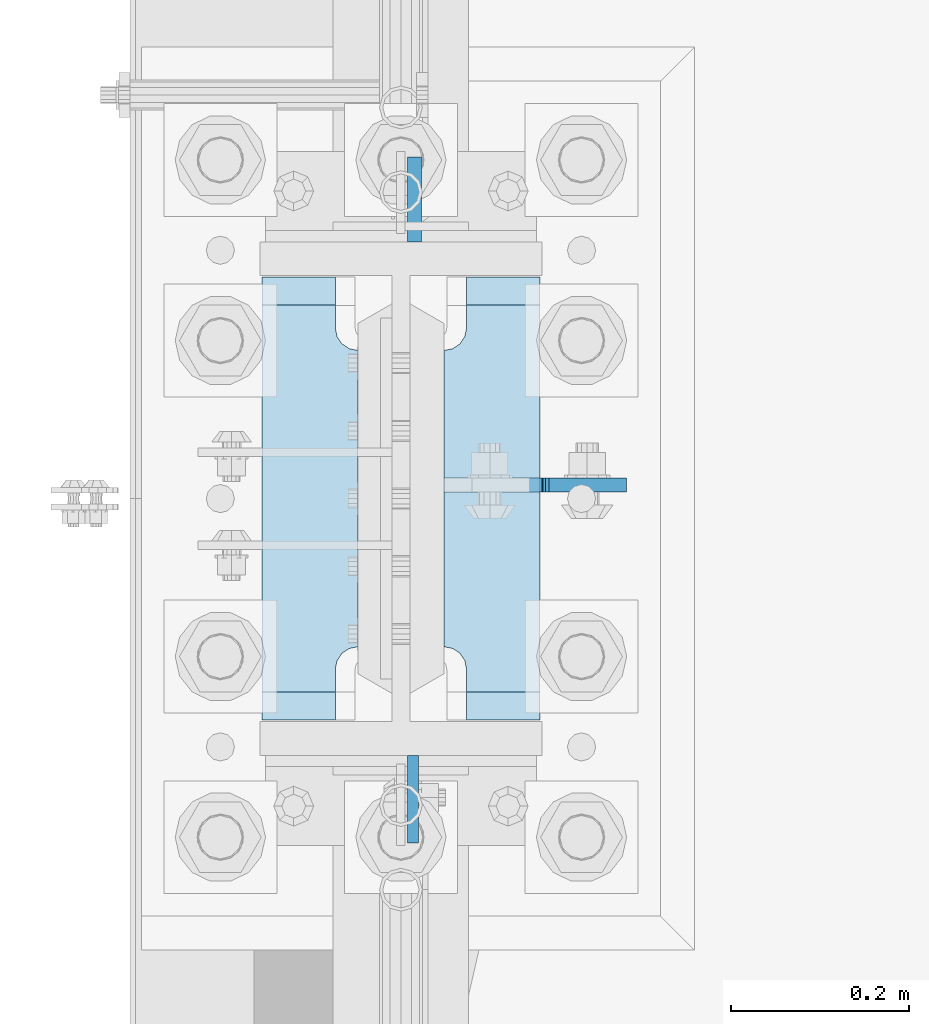
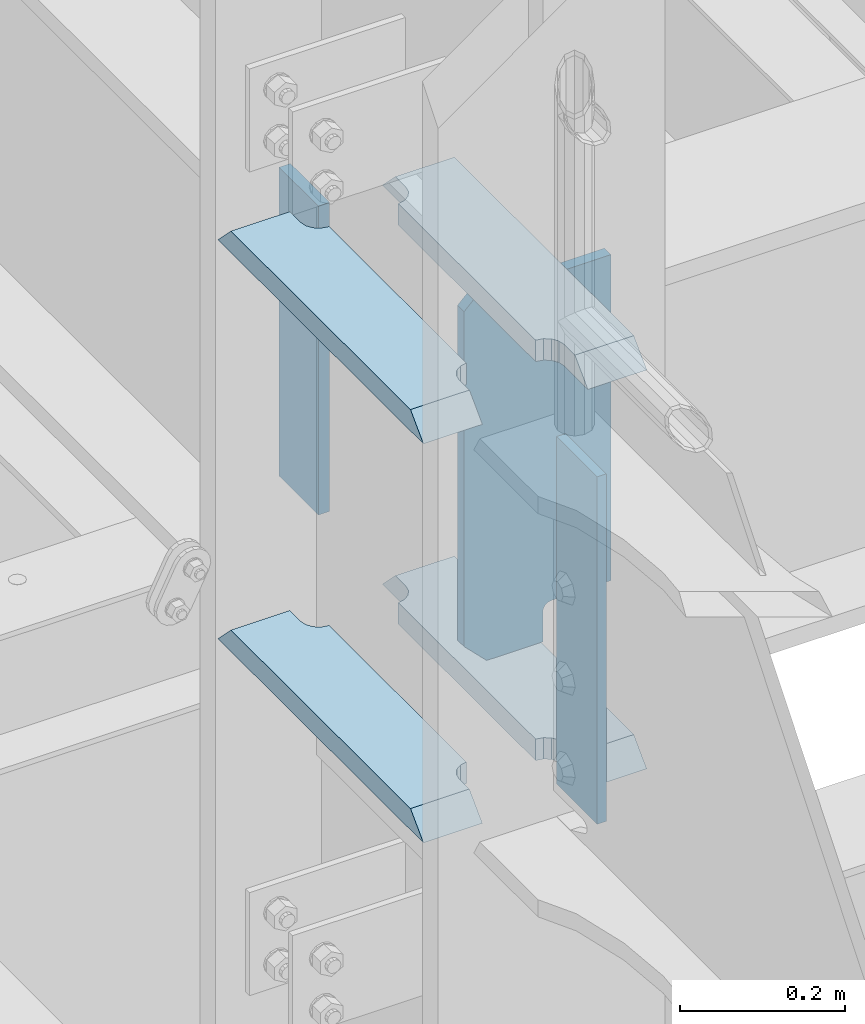
# One storey, part 1692 of 1876: 7 plates, 1 element without a shape of its own.
"""IFC2X3 building model written with IfcOpenShell, lengths in millimetres."""

from ifc_helpers import new_model, si_unit, frame, origin_with_axes, place, context, subcontext, project, spatial, faceted_brep, material, type_object, element, aggregate, save


model = new_model("IFC2X3")

# Units and contexts
model_context = context("Model", 3, precision=1e-05, world=origin_with_axes())
body_context = subcontext(model_context, "Body", "Model", "MODEL_VIEW")
ifc_project = project(units=[si_unit("LENGTHUNIT", "METRE", prefix="MILLI"), si_unit("AREAUNIT", "SQUARE_METRE"), si_unit("VOLUMEUNIT", "CUBIC_METRE"), si_unit("MASSUNIT", "GRAM", prefix="KILO"), si_unit("TIMEUNIT", "SECOND"), si_unit("PLANEANGLEUNIT", "RADIAN"), si_unit("SOLIDANGLEUNIT", "STERADIAN"), si_unit("THERMODYNAMICTEMPERATUREUNIT", "DEGREE_CELSIUS"), si_unit("LUMINOUSINTENSITYUNIT", "LUMEN")], contexts=[model_context])

# Site, building, storey
site_placement = place(None, origin_with_axes())
site = spatial("IfcSite", under=ifc_project, at=site_placement, CompositionType="ELEMENT")
building_placement = place(site_placement, origin_with_axes())
building = spatial("IfcBuilding", under=site, at=building_placement, Name="Undefined", CompositionType="ELEMENT")
storey_placement = place(building_placement, origin_with_axes())
storey = spatial("IfcBuildingStorey", under=building, at=storey_placement, Name="Undefined", CompositionType="ELEMENT", Elevation=0.0)

# Assembly, plates
assembly_placement = place(storey_placement, origin_with_axes())
assembly = element("IfcElementAssembly", 1, at=assembly_placement, inside=storey, Name="COLUMN", AssemblyPlace="NOTDEFINED", PredefinedType="RIGID_FRAME")
ifc_material_1 = material(Name="STEEL/A572-50")
plate_type_1 = type_object("IfcPlateType", PredefinedType="NOTDEFINED")
plate_1_placement = place(assembly_placement, frame((13.493000125885, 7331.075, 8099.425), z_axis=(0.0, -1.0, 0.0), x_axis=(0.0, 0.0, -1.0)))
plate_1 = element("IfcPlate", 2, at=plate_1_placement, type_object=plate_type_1, material=ifc_material_1, Name="PLATE", context=body_context, shape_type="Brep", body=[
    faceted_brep([(0.0, -6.35000000000036, 0.0), (0.0, -6.34999999999991, 98.4250030517578), (0.0, 6.34999999999991, 98.4250030517578), (0.0, 6.35000000000036, 0.0), (514.349975585938, -6.35000000000036, 98.4250030517578), (514.349975585938, 6.35000000000036, 98.4250030517578), (514.349975585938, -6.35000000000036, 0.0), (514.349975585938, 6.35000000000036, 0.0)], [[[0, 1, 2, 3]], [[1, 4, 5, 2]], [[4, 6, 7, 5]], [[6, 0, 3, 7]], [[5, 7, 3, 2]], [[6, 4, 1, 0]]]),
])
ifc_material_2 = material(Name="STEEL/A36")
plate_type_2 = type_object("IfcPlateType", PredefinedType="NOTDEFINED")
plate_2_placement = place(assembly_placement, frame((15.080500125885, 7908.925, 8089.9), z_axis=(0.0, 1.0, 0.0), x_axis=(0.0, 0.0, -1.0)))
plate_2 = element("IfcPlate", 3, at=plate_2_placement, type_object=plate_type_2, material=ifc_material_2, Name="PLATE", context=body_context, shape_type="Brep", body=[
    faceted_brep([(0.0, -7.9375, 0.0), (0.0, -7.9375, 95.25), (0.0, 7.9375, 95.25), (0.0, 7.9375, 0.0), (457.200012207031, -7.9375, 95.25), (457.200012207031, 7.9375, 95.25), (457.200012207031, -7.9375, 0.0), (457.200012207031, 7.9375, 0.0)], [[[0, 1, 2, 3]], [[1, 4, 5, 2]], [[4, 6, 7, 5]], [[6, 0, 3, 7]], [[5, 7, 3, 2]], [[6, 4, 1, 0]]]),
])
plate_type_3 = type_object("IfcPlateType", PredefinedType="NOTDEFINED")
plate_3_placement = place(assembly_placement, frame((-48.41875, 7370.7625, 7546.97501220703), z_axis=(0.0, 1.0, 0.0), x_axis=(-1.0, 0.0, 0.0)))
plate_3 = element("IfcPlate", 4, at=plate_3_placement, type_object=plate_type_3, material=ifc_material_1, Name="PLATE", context=body_context, shape_type="Brep", body=[
    faceted_brep([(107.949996948242, -15.875, 498.475006103516), (107.949996948242, 15.875, 467.025007631571), (25.3999996185303, 15.875, 467.025007631571), (25.3999996185303, -15.875, 498.475006103516), (23.4665397733561, -15.875, 431.604843634198), (25.3999996185303, -15.875, 441.325002670288), (25.3999996185303, 15.875, 441.325002670288), (23.4665397733561, 15.875, 431.604843634198), (17.9605119724001, -15.875, 423.36449069789), (17.9605119724001, 15.875, 423.36449069789), (9.72015903609281, -15.875, 417.858462896934), (9.72015903609281, 15.875, 417.858462896934), (0.0, -15.875, 415.925003051758), (0.0, 15.875, 415.925003051758), (0.0, -15.875, 82.5500030517578), (0.0, 15.875, 82.5500030517578), (9.72015903609099, -15.875, 80.616543206582), (9.72015903609099, 15.875, 80.616543206582), (17.9605119723983, -15.875, 75.1105154056258), (17.9605119723983, 15.875, 75.1105154056258), (23.4665397733552, -15.875, 66.8701624693183), (23.4665397733552, 15.875, 66.8701624693183), (25.3999996185303, -15.875, 57.1500034332275), (25.3999996185303, 15.875, 57.1500034332275), (25.3999996185303, 15.875, 31.449998471945), (25.3999996185303, -15.875, 0.0), (107.949996948242, 15.875, 31.449998471945), (107.949996948242, -15.875, 0.0)], [[[0, 1, 2, 3]], [[4, 5, 6, 7]], [[8, 4, 7, 9]], [[10, 8, 9, 11]], [[12, 10, 11, 13]], [[14, 12, 13, 15]], [[16, 14, 15, 17]], [[18, 16, 17, 19]], [[20, 18, 19, 21]], [[22, 20, 21, 23]], [[22, 23, 24, 25]], [[26, 27, 25, 24]], [[5, 4, 8, 10, 12, 14, 16, 18, 20, 22, 25, 27, 0, 3]], [[6, 5, 3, 2]], [[26, 24, 23, 21, 19, 17, 15, 13, 11, 9, 7, 6, 2, 1]], [[27, 26, 1, 0]]]),
])
plate_4_placement = place(assembly_placement, frame((-48.41875, 7370.7625, 8137.525), z_axis=(0.0, 1.0, 0.0), x_axis=(-1.0, 0.0, 0.0)))
plate_4 = element("IfcPlate", 5, at=plate_4_placement, type_object=plate_type_3, material=ifc_material_1, Name="PLATE", context=body_context, shape_type="Brep", body=[
    faceted_brep([(107.949996948242, -15.875, 498.475006103516), (107.949996948242, 15.875, 467.025007631571), (25.3999996185303, 15.875, 467.025007631571), (25.3999996185303, -15.875, 498.475006103516), (23.4665397733561, -15.875, 431.604843634198), (25.3999996185303, -15.875, 441.325002670288), (25.3999996185303, 15.875, 441.325002670288), (23.4665397733561, 15.875, 431.604843634198), (17.9605119724001, -15.875, 423.36449069789), (17.9605119724001, 15.875, 423.36449069789), (9.72015903609281, -15.875, 417.858462896934), (9.72015903609281, 15.875, 417.858462896934), (0.0, -15.875, 415.925003051758), (0.0, 15.875, 415.925003051758), (0.0, -15.875, 82.5500030517578), (0.0, 15.875, 82.5500030517578), (9.72015903609099, -15.875, 80.616543206582), (9.72015903609099, 15.875, 80.616543206582), (17.9605119723983, -15.875, 75.1105154056258), (17.9605119723983, 15.875, 75.1105154056258), (23.4665397733552, -15.875, 66.8701624693183), (23.4665397733552, 15.875, 66.8701624693183), (25.3999996185303, -15.875, 57.1500034332275), (25.3999996185303, 15.875, 57.1500034332275), (25.3999996185303, 15.875, 31.449998471945), (25.3999996185303, -15.875, 0.0), (107.949996948242, 15.875, 31.449998471945), (107.949996948242, -15.875, 0.0)], [[[0, 1, 2, 3]], [[4, 5, 6, 7]], [[8, 4, 7, 9]], [[10, 8, 9, 11]], [[12, 10, 11, 13]], [[14, 12, 13, 15]], [[16, 14, 15, 17]], [[18, 16, 17, 19]], [[20, 18, 19, 21]], [[22, 20, 21, 23]], [[22, 23, 24, 25]], [[26, 27, 25, 24]], [[5, 4, 8, 10, 12, 14, 16, 18, 20, 22, 25, 27, 0, 3]], [[6, 5, 3, 2]], [[26, 24, 23, 21, 19, 17, 15, 13, 11, 9, 7, 6, 2, 1]], [[27, 26, 1, 0]]]),
])
plate_5_placement = place(assembly_placement, frame((156.36875, 7370.7625, 7546.97501220703), z_axis=(0.0, 1.0, 0.0), x_axis=(-1.0, 0.0, 0.0)))
plate_5 = element("IfcPlate", 6, at=plate_5_placement, type_object=plate_type_3, material=ifc_material_1, Name="PLATE", context=body_context, shape_type="Brep", body=[
    faceted_brep([(82.5499973297119, -15.875, 498.475006103516), (82.5499973297119, 15.875, 467.025007631571), (0.0, 15.875, 467.025007631571), (0.0, -15.875, 498.475006103516), (82.5499973297119, 15.875, 31.449998471945), (82.5499973297119, -15.875, 0.0), (0.0, -15.875, 0.0), (0.0, 15.875, 31.449998471945), (82.5499973297119, 15.875, 57.1500034332275), (82.5499973297119, -15.875, 57.1500034332275), (84.4834571748879, -15.875, 66.8701624693188), (84.4834571748879, 15.875, 66.8701624693188), (89.9894849758439, -15.875, 75.1105154056261), (89.9894849758439, 15.875, 75.1105154056261), (98.2298379121512, -15.875, 80.616543206582), (98.2298379121512, 15.875, 80.616543206582), (107.949996948242, -15.875, 82.5500030517578), (107.949996948242, 15.875, 82.5500030517578), (107.949996948242, -15.875, 415.925003051758), (107.949996948242, 15.875, 415.925003051758), (98.2298379121512, -15.875, 417.858462896934), (98.2298379121512, 15.875, 417.858462896934), (89.9894849758439, -15.875, 423.36449069789), (89.9894849758439, 15.875, 423.36449069789), (84.483457174887, -15.875, 431.604843634197), (84.483457174887, 15.875, 431.604843634197), (82.5499973297119, -15.875, 441.325002670288), (82.5499973297119, 15.875, 441.325002670288)], [[[0, 1, 2, 3]], [[4, 5, 6, 7]], [[8, 9, 5, 4]], [[10, 9, 8, 11]], [[12, 10, 11, 13]], [[14, 12, 13, 15]], [[16, 14, 15, 17]], [[18, 16, 17, 19]], [[20, 18, 19, 21]], [[22, 20, 21, 23]], [[24, 22, 23, 25]], [[26, 24, 25, 27]], [[6, 5, 9, 10, 12, 14, 16, 18, 20, 22, 24, 26, 0, 3]], [[7, 6, 3, 2]], [[27, 25, 23, 21, 19, 17, 15, 13, 11, 8, 4, 7, 2, 1]], [[26, 27, 1, 0]]]),
])
plate_6_placement = place(assembly_placement, frame((156.36875, 7370.7625, 8137.525), z_axis=(0.0, 1.0, 0.0), x_axis=(-1.0, 0.0, 0.0)))
plate_6 = element("IfcPlate", 7, at=plate_6_placement, type_object=plate_type_3, material=ifc_material_1, Name="PLATE", context=body_context, shape_type="Brep", body=[
    faceted_brep([(82.5499973297119, -15.875, 498.475006103516), (82.5499973297119, 15.875, 467.025007631571), (0.0, 15.875, 467.025007631571), (0.0, -15.875, 498.475006103516), (82.5499973297119, 15.875, 31.449998471945), (82.5499973297119, -15.875, 0.0), (0.0, -15.875, 0.0), (0.0, 15.875, 31.449998471945), (82.5499973297119, 15.875, 57.1500034332275), (82.5499973297119, -15.875, 57.1500034332275), (84.4834571748879, -15.875, 66.8701624693188), (84.4834571748879, 15.875, 66.8701624693188), (89.9894849758439, -15.875, 75.1105154056261), (89.9894849758439, 15.875, 75.1105154056261), (98.2298379121512, -15.875, 80.616543206582), (98.2298379121512, 15.875, 80.616543206582), (107.949996948242, -15.875, 82.5500030517578), (107.949996948242, 15.875, 82.5500030517578), (107.949996948242, -15.875, 415.925003051758), (107.949996948242, 15.875, 415.925003051758), (98.2298379121512, -15.875, 417.858462896934), (98.2298379121512, 15.875, 417.858462896934), (89.9894849758439, -15.875, 423.36449069789), (89.9894849758439, 15.875, 423.36449069789), (84.483457174887, -15.875, 431.604843634197), (84.483457174887, 15.875, 431.604843634197), (82.5499973297119, -15.875, 441.325002670288), (82.5499973297119, 15.875, 441.325002670288)], [[[0, 1, 2, 3]], [[4, 5, 6, 7]], [[8, 9, 5, 4]], [[10, 9, 8, 11]], [[12, 10, 11, 13]], [[14, 12, 13, 15]], [[16, 14, 15, 17]], [[18, 16, 17, 19]], [[20, 18, 19, 21]], [[22, 20, 21, 23]], [[24, 22, 23, 25]], [[26, 24, 25, 27]], [[6, 5, 9, 10, 12, 14, 16, 18, 20, 22, 24, 26, 0, 3]], [[7, 6, 3, 2]], [[27, 25, 23, 21, 19, 17, 15, 13, 11, 8, 4, 7, 2, 1]], [[26, 27, 1, 0]]]),
])
plate_type_4 = type_object("IfcPlateType", PredefinedType="NOTDEFINED")
plate_7_placement = place(assembly_placement, frame((48.4187500000002, 7635.08125, 8121.65), z_axis=(1.0, 0.0, 0.0), x_axis=(0.0, 0.0, -1.0)))
plate_7 = element("IfcPlate", 8, at=plate_7_placement, type_object=plate_type_4, material=ifc_material_2, Name="PLATE", context=body_context, shape_type="Brep", body=[
    faceted_brep([(501.650012207032, -7.9375, 205.581252728631), (501.650012207032, -7.9375, 123.031246757509), (501.650012207032, 7.9375, 123.031246757509), (501.650012207032, 7.9375, 205.581253051758), (502.61674212962, -7.9375, 118.171167239463), (502.61674212962, 7.9375, 118.171167239463), (505.369756030097, -7.9375, 114.050990771309), (505.369756030097, 7.9375, 114.050990771309), (509.489932498251, -7.9375, 111.297976870831), (509.489932498251, 7.9375, 111.297976870831), (514.350012016297, -7.9375, 110.331246948243), (514.350012016297, 7.9375, 110.331246948243), (558.799987792969, -7.9375, 110.331246948243), (558.799987792969, 7.9375, 110.331246948243), (19.0499992370605, -7.9375, 205.58125), (19.0499992370605, 7.9375, 205.581253051758), (19.0499992370605, 7.9375, 123.031249809265), (19.0499992370605, -7.9375, 123.031249809265), (18.083269314473, 7.9375, 118.17117029122), (18.083269314473, -7.9375, 118.17117029122), (15.3302554139955, 7.9375, 114.050993823066), (15.3302554139955, -7.9375, 114.050993823066), (11.2100789458418, 7.9375, 111.297979922588), (11.2100789458418, -7.9375, 111.297979922588), (6.34999942779541, 7.9375, 110.33125), (6.34999942779541, -7.9375, 110.33125), (0.0, 7.9375, 110.33125), (0.0, -7.9375, 110.33125), (0.0, 7.93749999999999, 31.75), (0.0, -7.93749999999998, 31.75), (31.75, -7.93749999999998, 0.0), (31.75, 7.93749999999999, 0.0), (527.049987792969, -7.93749999999998, 0.0), (527.049987792969, 7.93749999999999, 0.0), (558.799987792969, -7.93749999999998, 31.75), (558.799987792969, 7.93749999999999, 31.75)], [[[0, 1, 2, 3]], [[4, 5, 2, 1]], [[6, 7, 5, 4]], [[8, 9, 7, 6]], [[10, 11, 9, 8]], [[12, 13, 11, 10]], [[14, 15, 16, 17]], [[17, 16, 18, 19]], [[19, 18, 20, 21]], [[21, 20, 22, 23]], [[23, 22, 24, 25]], [[25, 24, 26, 27]], [[28, 29, 27, 26]], [[30, 29, 28, 31]], [[32, 30, 31, 33]], [[34, 32, 33, 35]], [[8, 6, 4, 1, 0, 14, 17, 19, 21, 23, 25, 27, 29, 30, 32, 34, 12, 10]], [[15, 14, 0, 3]], [[35, 33, 31, 28, 26, 24, 22, 20, 18, 16, 15, 3, 2, 5, 7, 9, 11, 13]], [[34, 35, 13, 12]]]),
])
aggregate(assembly, [plate_1, plate_3, plate_4, plate_5, plate_6, plate_7, plate_2])

save(model, "model.ifc")
